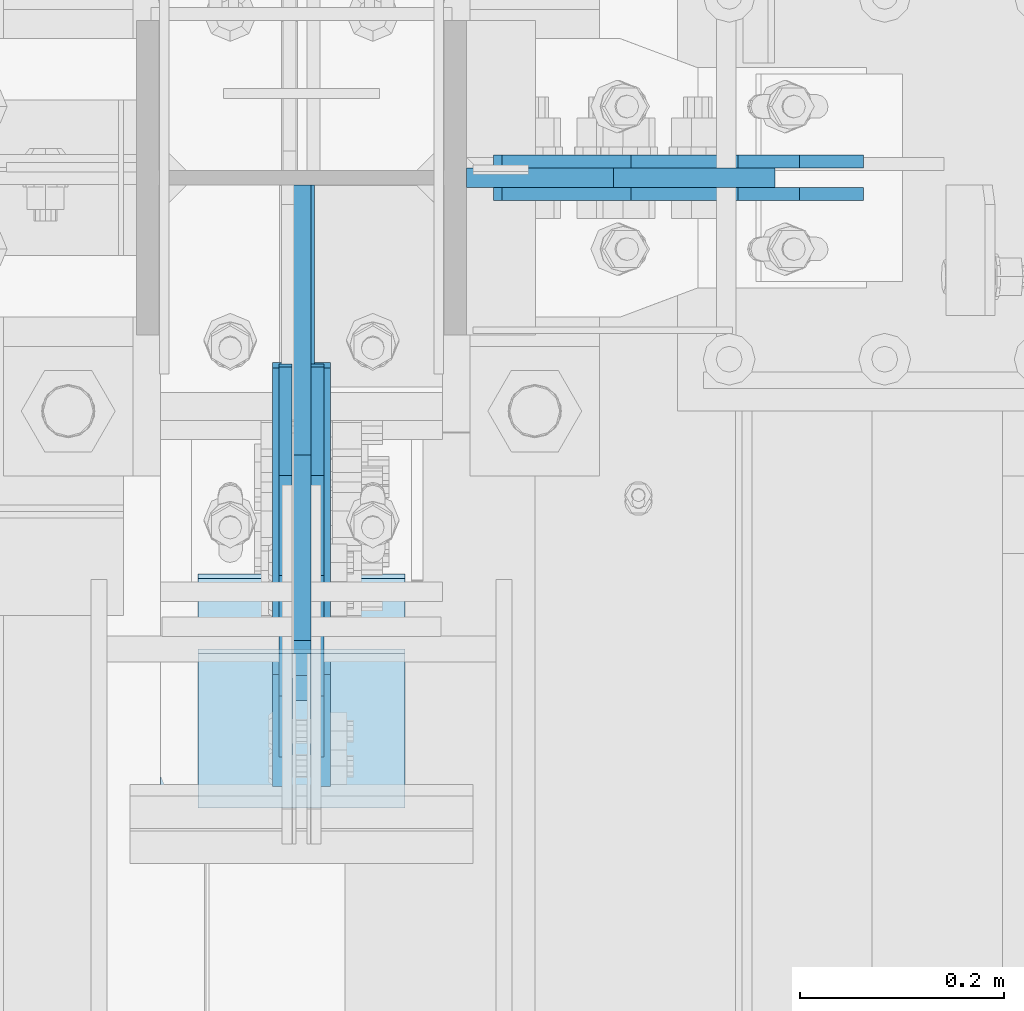
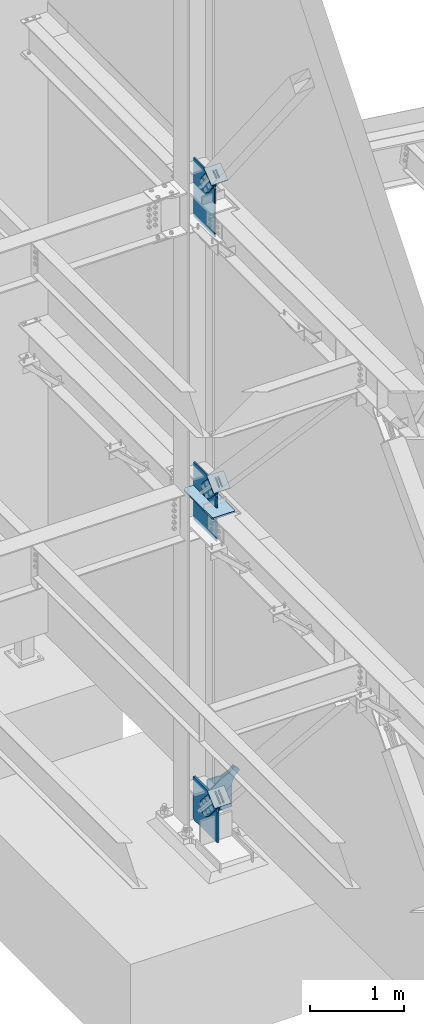
# One storey, part 1090 of 1179: 16 plates, 12 elements without a shape of their own.
"""IFC2X3 building model written with IfcOpenShell, lengths in millimetres."""

from ifc_helpers import new_model, si_unit, frame, origin_with_axes, place, context, subcontext, project, spatial, faceted_brep, material, type_object, element, aggregate, save


model = new_model("IFC2X3")

# Units and contexts
model_context = context("Model", 3, precision=1e-05, world=origin_with_axes())
body_context = subcontext(model_context, "Body", "Model", "MODEL_VIEW")
ifc_project = project(units=[si_unit("LENGTHUNIT", "METRE", prefix="MILLI"), si_unit("AREAUNIT", "SQUARE_METRE"), si_unit("VOLUMEUNIT", "CUBIC_METRE"), si_unit("MASSUNIT", "GRAM", prefix="KILO"), si_unit("TIMEUNIT", "SECOND"), si_unit("PLANEANGLEUNIT", "RADIAN"), si_unit("SOLIDANGLEUNIT", "STERADIAN"), si_unit("THERMODYNAMICTEMPERATUREUNIT", "DEGREE_CELSIUS"), si_unit("LUMINOUSINTENSITYUNIT", "LUMEN")], contexts=[model_context])

# Site, building, storey
site_placement = place(None, origin_with_axes())
site = spatial("IfcSite", under=ifc_project, at=site_placement, CompositionType="ELEMENT")
building_placement = place(site_placement, origin_with_axes())
building = spatial("IfcBuilding", under=site, at=building_placement, Name="Undefined", CompositionType="ELEMENT")
storey_placement = place(building_placement, origin_with_axes())
storey = spatial("IfcBuildingStorey", under=building, at=storey_placement, Name="Undefined", CompositionType="ELEMENT", Elevation=0.0)

# Assembly, plate
assembly_1_placement = place(storey_placement, origin_with_axes())
assembly_1 = element("IfcElementAssembly", 1, at=assembly_1_placement, inside=storey, AssemblyPlace="NOTDEFINED", PredefinedType="RIGID_FRAME")
ifc_material_1 = material(Name="STEEL/A36")
plate_type_1 = type_object("IfcPlateType", PredefinedType="NOTDEFINED")
plate_1_placement = place(assembly_1_placement, frame((24798.1057246051, 34407.475, 178.905330865056), z_axis=(-0.682177697050866, 0.0, 0.731186426054517), x_axis=(0.73118642605452, 0.0, 0.682177697050862)))
plate_1 = element("IfcPlate", 2, at=plate_1_placement, type_object=plate_type_1, material=ifc_material_1, context=body_context, shape_type="Brep", body=[
    faceted_brep([(0.0, -6.34999999999854, 0.0), (-101.600000000211, -6.34999999999854, -44.6881937825565), (-101.600000000211, 6.34999999999854, -44.6881937825565), (0.0, 6.34999999999854, 0.0), (-246.684985848258, -6.34999999999854, -44.6881937827675), (-246.684985848258, 6.34999999999854, -44.6881937827675), (-281.313054102191, -6.34999999999854, -37.800242748639), (-281.313054102191, 6.34999999999854, -37.800242748639), (-310.669312868691, -6.34999999999854, -18.1850177516608), (-310.669312868691, 6.34999999999854, -18.1850177516608), (-330.284537865713, -6.34999999999854, 11.1712410148393), (-330.284537865713, 6.34999999999854, 11.1712410148393), (-337.172488899912, -6.34999999999854, 45.7993031647638), (-337.172488899912, 6.34999999999854, 45.7993031647638), (-330.284537865768, -6.34999999999854, 80.4273714187839), (-330.284537865768, 6.34999999999854, 80.4273714187839), (-310.669312868773, -6.34999999999854, 109.783630185371), (-310.669312868773, 6.34999999999854, 109.783630185371), (-281.313054102271, -6.34999999999854, 129.398855182466), (-281.313054102271, 6.34999999999854, 129.398855182466), (-246.684988899762, -6.34999999999854, 136.286806216707), (-246.684988899762, 6.34999999999854, 136.286806216707), (-101.600000000377, -6.34999999999854, 136.286806216911), (-101.600000000377, 6.34999999999854, 136.286806216911), (-8.18545231595635e-11, -6.34999999999854, 91.5986124346418), (-8.18545231595635e-11, 6.34999999999854, 91.5986124346418), (82.5500000001266, -6.34999999999854, 91.5986124347546), (82.5500000001266, 6.34999999999854, 91.5986124347546), (82.550000000203, -6.34999999999854, 1.2732925824821e-10), (82.550000000203, 6.34999999999854, 1.2732925824821e-10)], [[[0, 1, 2, 3]], [[1, 4, 5, 2]], [[4, 6, 7, 5]], [[6, 8, 9, 7]], [[8, 10, 11, 9]], [[10, 12, 13, 11]], [[12, 14, 15, 13]], [[14, 16, 17, 15]], [[16, 18, 19, 17]], [[18, 20, 21, 19]], [[20, 22, 23, 21]], [[22, 24, 25, 23]], [[24, 26, 27, 25]], [[26, 28, 29, 27]], [[28, 0, 3, 29]], [[5, 7, 9, 11, 13, 15, 17, 19, 21, 23, 25, 27, 29, 3, 2]], [[28, 26, 24, 22, 20, 18, 16, 14, 12, 10, 8, 6, 4, 1, 0]]]),
])
aggregate(assembly_1, [plate_1])

assembly_2_placement = place(storey_placement, origin_with_axes())
assembly_2 = element("IfcElementAssembly", 3, at=assembly_2_placement, inside=storey, AssemblyPlace="NOTDEFINED", PredefinedType="RIGID_FRAME")
plate_2_placement = place(assembly_2_placement, frame((24798.1057246051, 34375.725, 178.905330865056), z_axis=(-0.682177697050866, 0.0, 0.731186426054517), x_axis=(0.73118642605452, 0.0, 0.682177697050862)))
plate_2 = element("IfcPlate", 4, at=plate_2_placement, type_object=plate_type_1, material=ifc_material_1, context=body_context, shape_type="Brep", body=[
    faceted_brep([(0.0, -6.34999999999854, 0.0), (-101.600000000211, -6.34999999999854, -44.6881937825565), (-101.600000000211, 6.34999999999854, -44.6881937825565), (0.0, 6.34999999999854, 0.0), (-246.684985848258, -6.34999999999854, -44.6881937827675), (-246.684985848258, 6.34999999999854, -44.6881937827675), (-281.313054102191, -6.34999999999854, -37.800242748639), (-281.313054102191, 6.34999999999854, -37.800242748639), (-310.669312868691, -6.34999999999854, -18.1850177516608), (-310.669312868691, 6.34999999999854, -18.1850177516608), (-330.284537865713, -6.34999999999854, 11.1712410148393), (-330.284537865713, 6.34999999999854, 11.1712410148393), (-337.172488899912, -6.34999999999854, 45.7993031647638), (-337.172488899912, 6.34999999999854, 45.7993031647638), (-330.284537865768, -6.34999999999854, 80.4273714187839), (-330.284537865768, 6.34999999999854, 80.4273714187839), (-310.669312868773, -6.34999999999854, 109.783630185371), (-310.669312868773, 6.34999999999854, 109.783630185371), (-281.313054102271, -6.34999999999854, 129.398855182466), (-281.313054102271, 6.34999999999854, 129.398855182466), (-246.684988899762, -6.34999999999854, 136.286806216707), (-246.684988899762, 6.34999999999854, 136.286806216707), (-101.600000000377, -6.34999999999854, 136.286806216911), (-101.600000000377, 6.34999999999854, 136.286806216911), (-8.18545231595635e-11, -6.34999999999854, 91.5986124346418), (-8.18545231595635e-11, 6.34999999999854, 91.5986124346418), (82.5500000001266, -6.34999999999854, 91.5986124347546), (82.5500000001266, 6.34999999999854, 91.5986124347546), (82.550000000203, -6.34999999999854, 1.2732925824821e-10), (82.550000000203, 6.34999999999854, 1.2732925824821e-10)], [[[0, 1, 2, 3]], [[1, 4, 5, 2]], [[4, 6, 7, 5]], [[6, 8, 9, 7]], [[8, 10, 11, 9]], [[10, 12, 13, 11]], [[12, 14, 15, 13]], [[14, 16, 17, 15]], [[16, 18, 19, 17]], [[18, 20, 21, 19]], [[20, 22, 23, 21]], [[22, 24, 25, 23]], [[24, 26, 27, 25]], [[26, 28, 29, 27]], [[28, 0, 3, 29]], [[5, 7, 9, 11, 13, 15, 17, 19, 21, 23, 25, 27, 29, 3, 2]], [[28, 26, 24, 22, 20, 18, 16, 14, 12, 10, 8, 6, 4, 1, 0]]]),
])
aggregate(assembly_2, [plate_2])

assembly_3_placement = place(storey_placement, origin_with_axes())
assembly_3 = element("IfcElementAssembly", 5, at=assembly_3_placement, inside=storey, AssemblyPlace="NOTDEFINED", PredefinedType="RIGID_FRAME")
plate_3_placement = place(assembly_3_placement, frame((24291.925, 33955.4297504539, 8429.1005762594), z_axis=(0.0, -0.784153429306135, -0.620566998242276), x_axis=(0.0, 0.620566998242269, -0.78415342930614)))
plate_3 = element("IfcPlate", 6, at=plate_3_placement, type_object=plate_type_1, material=ifc_material_1, context=body_context, shape_type="Brep", body=[
    faceted_brep([(0.0, -6.34999999999854, 0.0), (-8.18545231595635e-11, -6.34999999999854, 91.5986124346418), (-8.18545231595635e-11, 6.34999999999854, 91.5986124346418), (0.0, 6.34999999999854, 0.0), (74.9300000003022, -6.34999999999854, 91.5986124341325), (74.9300000003022, 6.34999999999854, 91.5986124341325), (176.530000001621, -6.34999999999854, 136.28680621547), (176.530000001621, 6.34999999999854, 136.28680621547), (321.614985851276, -6.34999999999854, 136.286806215194), (321.614985851276, 6.34999999999854, 136.286806215194), (356.243054105249, -6.34999999999854, 129.398855180967), (356.243054105249, 6.34999999999854, 129.398855180967), (385.599312871764, -6.34999999999854, 109.78363018396), (385.599312871764, 6.34999999999854, 109.78363018396), (405.214537868786, -6.34999999999854, 80.4273714174888), (405.214537868786, 6.34999999999854, 80.4273714174888), (412.10248890298, -6.34999999999854, 45.7993092690194), (412.10248890298, 6.34999999999854, 45.7993092690194), (405.214537868789, -6.34999999999854, 11.1712410150285), (405.214537868789, 6.34999999999854, 11.1712410150285), (385.599312871695, -6.34999999999854, -18.1850177515043), (385.599312871695, 6.34999999999854, -18.1850177515043), (356.243054105063, -6.34999999999854, -37.8002427485044), (356.243054105063, 6.34999999999854, -37.8002427485044), (321.614988902153, -6.34999999999854, -44.6881937826292), (321.614988902153, 6.34999999999854, -44.6881937826292), (176.530000001738, -6.34999999999854, -44.6881937823491), (176.530000001738, 6.34999999999854, -44.6881937823491), (74.9300000005605, -6.34999999999854, 6.91215973347425e-11), (74.9300000005605, 6.34999999999854, 6.91215973347425e-11)], [[[0, 1, 2, 3]], [[1, 4, 5, 2]], [[4, 6, 7, 5]], [[6, 8, 9, 7]], [[8, 10, 11, 9]], [[10, 12, 13, 11]], [[12, 14, 15, 13]], [[14, 16, 17, 15]], [[16, 18, 19, 17]], [[18, 20, 21, 19]], [[20, 22, 23, 21]], [[22, 24, 25, 23]], [[24, 26, 27, 25]], [[26, 28, 29, 27]], [[28, 0, 3, 29]], [[5, 7, 9, 11, 13, 15, 17, 19, 21, 23, 25, 27, 29, 3, 2]], [[28, 26, 24, 22, 20, 18, 16, 14, 12, 10, 8, 6, 4, 1, 0]]]),
])
aggregate(assembly_3, [plate_3])

assembly_4_placement = place(storey_placement, origin_with_axes())
assembly_4 = element("IfcElementAssembly", 7, at=assembly_4_placement, inside=storey, AssemblyPlace="NOTDEFINED", PredefinedType="RIGID_FRAME")
plate_4_placement = place(assembly_4_placement, frame((24323.675, 33955.4297504539, 8429.1005762594), z_axis=(0.0, -0.784153429306135, -0.620566998242276), x_axis=(0.0, 0.620566998242269, -0.78415342930614)))
plate_4 = element("IfcPlate", 8, at=plate_4_placement, type_object=plate_type_1, material=ifc_material_1, context=body_context, shape_type="Brep", body=[
    faceted_brep([(0.0, -6.34999999999854, 0.0), (-8.18545231595635e-11, -6.34999999999854, 91.5986124346418), (-8.18545231595635e-11, 6.34999999999854, 91.5986124346418), (0.0, 6.34999999999854, 0.0), (74.9300000003022, -6.34999999999854, 91.5986124341325), (74.9300000003022, 6.34999999999854, 91.5986124341325), (176.530000001621, -6.34999999999854, 136.28680621547), (176.530000001621, 6.34999999999854, 136.28680621547), (321.614985851276, -6.34999999999854, 136.286806215194), (321.614985851276, 6.34999999999854, 136.286806215194), (356.243054105249, -6.34999999999854, 129.398855180967), (356.243054105249, 6.34999999999854, 129.398855180967), (385.599312871764, -6.34999999999854, 109.78363018396), (385.599312871764, 6.34999999999854, 109.78363018396), (405.214537868786, -6.34999999999854, 80.4273714174888), (405.214537868786, 6.34999999999854, 80.4273714174888), (412.10248890298, -6.34999999999854, 45.7993092690194), (412.10248890298, 6.34999999999854, 45.7993092690194), (405.214537868789, -6.34999999999854, 11.1712410150285), (405.214537868789, 6.34999999999854, 11.1712410150285), (385.599312871695, -6.34999999999854, -18.1850177515043), (385.599312871695, 6.34999999999854, -18.1850177515043), (356.243054105063, -6.34999999999854, -37.8002427485044), (356.243054105063, 6.34999999999854, -37.8002427485044), (321.614988902153, -6.34999999999854, -44.6881937826292), (321.614988902153, 6.34999999999854, -44.6881937826292), (176.530000001738, -6.34999999999854, -44.6881937823491), (176.530000001738, 6.34999999999854, -44.6881937823491), (74.9300000005605, -6.34999999999854, 6.91215973347425e-11), (74.9300000005605, 6.34999999999854, 6.91215973347425e-11)], [[[0, 1, 2, 3]], [[1, 4, 5, 2]], [[4, 6, 7, 5]], [[6, 8, 9, 7]], [[8, 10, 11, 9]], [[10, 12, 13, 11]], [[12, 14, 15, 13]], [[14, 16, 17, 15]], [[16, 18, 19, 17]], [[18, 20, 21, 19]], [[20, 22, 23, 21]], [[22, 24, 25, 23]], [[24, 26, 27, 25]], [[26, 28, 29, 27]], [[28, 0, 3, 29]], [[5, 7, 9, 11, 13, 15, 17, 19, 21, 23, 25, 27, 29, 3, 2]], [[28, 26, 24, 22, 20, 18, 16, 14, 12, 10, 8, 6, 4, 1, 0]]]),
])
aggregate(assembly_4, [plate_4])

assembly_5_placement = place(storey_placement, origin_with_axes())
assembly_5 = element("IfcElementAssembly", 9, at=assembly_5_placement, inside=storey, Name="Plate", AssemblyPlace="NOTDEFINED", PredefinedType="RIGID_FRAME")
plate_type_2 = type_object("IfcPlateType", PredefinedType="NOTDEFINED")
plate_5_placement = place(assembly_5_placement, frame((24206.2, 33841.816379224, 8335.13974412105), z_axis=(0.0, 0.784153429306134, 0.620566998242277), x_axis=(1.0, 0.0, 0.0)))
plate_5 = element("IfcPlate", 10, at=plate_5_placement, type_object=plate_type_2, material=ifc_material_1, Name="Plate", context=body_context, shape_type="Brep", body=[
    faceted_brep([(0.0, -3.17500000000109, 0.0), (0.0, -3.17500000000291, 203.200000000368), (0.0, 3.17499999998836, 203.200000000361), (0.0, 3.17500000000109, 7.27595761418343e-12), (203.199999999997, -3.17500000000291, 203.200000000368), (203.199999999997, 3.17499999998836, 203.200000000361), (203.199999999997, -3.17499999999927, 3.63797880709171e-12), (203.199999999997, 3.17499999999382, -3.63797880709171e-12)], [[[0, 1, 2, 3]], [[1, 4, 5, 2]], [[4, 6, 7, 5]], [[6, 0, 3, 7]], [[5, 7, 3, 2]], [[6, 4, 1, 0]]]),
])
aggregate(assembly_5, [plate_5])

assembly_6_placement = place(storey_placement, origin_with_axes())
assembly_6 = element("IfcElementAssembly", 11, at=assembly_6_placement, inside=storey, Name="Plate", AssemblyPlace="NOTDEFINED", PredefinedType="RIGID_FRAME")
plate_6_placement = place(assembly_6_placement, frame((24206.2, 33792.918136432, 4382.10915289215), z_axis=(0.0, 0.729241792887681, 0.684256097894612), x_axis=(1.0, 0.0, 0.0)))
plate_6 = element("IfcPlate", 12, at=plate_6_placement, type_object=plate_type_2, material=ifc_material_1, Name="Plate", context=body_context, shape_type="Brep", body=[
    faceted_brep([(0.0, -3.17500000000109, 0.0), (0.0, -3.17500000000291, 203.200000000368), (0.0, 3.17499999998836, 203.200000000361), (0.0, 3.17500000000109, 7.27595761418343e-12), (203.199999999997, -3.17500000000291, 203.200000000368), (203.199999999997, 3.17499999998836, 203.200000000361), (203.199999999997, -3.17499999999927, 3.63797880709171e-12), (203.199999999997, 3.17499999999382, -3.63797880709171e-12)], [[[0, 1, 2, 3]], [[1, 4, 5, 2]], [[4, 6, 7, 5]], [[6, 0, 3, 7]], [[5, 7, 3, 2]], [[6, 4, 1, 0]]]),
])
aggregate(assembly_6, [plate_6])

assembly_7_placement = place(storey_placement, origin_with_axes())
assembly_7 = element("IfcElementAssembly", 13, at=assembly_7_placement, inside=storey, Name="Plate", AssemblyPlace="NOTDEFINED", PredefinedType="RIGID_FRAME")
plate_7_placement = place(assembly_7_placement, frame((24206.2, 33776.2283892887, 320.431185750051), z_axis=(0.0, 0.745753571678113, 0.666221892712434), x_axis=(1.0, 0.0, 0.0)))
plate_7 = element("IfcPlate", 14, at=plate_7_placement, type_object=plate_type_2, material=ifc_material_1, Name="Plate", context=body_context, shape_type="Brep", body=[
    faceted_brep([(0.0, -3.17500000000109, 0.0), (0.0, -3.17500000000291, 203.200000000368), (0.0, 3.17499999998836, 203.200000000361), (0.0, 3.17500000000109, 7.27595761418343e-12), (203.199999999997, -3.17500000000291, 203.200000000368), (203.199999999997, 3.17499999998836, 203.200000000361), (203.199999999997, -3.17499999999927, 3.63797880709171e-12), (203.199999999997, 3.17499999999382, -3.63797880709171e-12)], [[[0, 1, 2, 3]], [[1, 4, 5, 2]], [[4, 6, 7, 5]], [[6, 0, 3, 7]], [[5, 7, 3, 2]], [[6, 4, 1, 0]]]),
])
aggregate(assembly_7, [plate_7])

# Assembly, plates
assembly_8_placement = place(storey_placement, origin_with_axes())
assembly_8 = element("IfcElementAssembly", 15, at=assembly_8_placement, inside=storey, Name="COLUMN", AssemblyPlace="NOTDEFINED", PredefinedType="RIGID_FRAME")
ifc_material_2 = material(Name="STEEL/A572-GR.50")
plate_type_3 = type_object("IfcPlateType", PredefinedType="NOTDEFINED")
plate_8_placement = place(assembly_8_placement, frame((24169.6874938965, 33751.6169989338, 4090.9875), z_axis=(0.0, 1.0, 0.0), x_axis=(1.0, 0.0, 0.0)))
plate_8 = element("IfcPlate", 16, at=plate_8_placement, type_object=plate_type_3, material=ifc_material_2, Name="PLATE", context=body_context, shape_type="Brep", body=[
    faceted_brep([(127.000006103513, -11.1125000000002, 632.839251066151), (127.000006103513, -11.1125000000002, 153.987500190735), (127.000006103513, 11.1125000000002, 153.987500190735), (127.000006103513, 11.1125000000002, 632.839251066151), (127.845894812999, -11.1125000000002, 149.734930475584), (127.845894812999, 11.1125000000002, 149.734930475584), (130.254782053442, -11.1125000000002, 146.129775949928), (130.254782053442, 11.1125000000002, 146.129775949928), (133.859936579101, -11.1125000000002, 143.720888709489), (133.859936579101, 11.1125000000002, 143.720888709489), (138.112505912784, -11.1125000000002, 142.875), (138.112505912784, 11.1125000000002, 142.875), (142.365075627931, -11.1125000000002, 143.720888709489), (142.365075627931, 11.1125000000002, 143.720888709489), (145.970230153591, -11.1125000000002, 146.129775949928), (145.970230153591, 11.1125000000002, 146.129775949928), (148.379117394034, -11.1125000000002, 149.734930475584), (148.379117394034, 11.1125000000002, 149.734930475584), (149.225006103519, -11.1125000000002, 153.987500190735), (149.225006103519, 11.1125000000002, 153.987500190735), (149.225006103519, -11.1125000000002, 632.839251066151), (149.225006103519, 11.1125000000002, 632.839251066151), (0.0, -11.1125000000002, 607.43925144762), (25.3999996185303, -11.1125000000002, 632.839251066151), (25.3999996185303, 11.1125000000002, 632.839251066151), (0.0, 11.1125000000002, 607.43925144762), (0.0, -11.1125000000002, 19.0499992370605), (0.0, 11.1125000000002, 19.0499992370605), (7.9375, -11.1125000000002, 0.0), (7.9375, 11.1125000000002, 0.0), (268.287506103516, -11.1125000000002, 0.0), (268.287506103516, 11.1125000000002, 0.0), (276.225006103516, -11.1125000000002, 19.0499992370605), (276.225006103516, 11.1125000000002, 19.0499992370605), (276.225006103516, -11.1125000000002, 607.43925144762), (276.225006103516, 11.1125000000002, 607.43925144762), (250.825006484985, -11.1125000000002, 632.839251066151), (250.825006484985, 11.1125000000002, 632.839251066151)], [[[0, 1, 2, 3]], [[4, 5, 2, 1]], [[6, 7, 5, 4]], [[8, 9, 7, 6]], [[10, 11, 9, 8]], [[12, 13, 11, 10]], [[14, 15, 13, 12]], [[16, 17, 15, 14]], [[18, 19, 17, 16]], [[20, 21, 19, 18]], [[22, 23, 24, 25]], [[26, 22, 25, 27]], [[28, 26, 27, 29]], [[30, 28, 29, 31]], [[32, 30, 31, 33]], [[34, 32, 33, 35]], [[36, 34, 35, 37]], [[16, 14, 12, 10, 8, 6, 4, 1, 0, 23, 22, 26, 28, 30, 32, 34, 36, 20, 18]], [[24, 23, 0, 3]], [[37, 35, 33, 31, 29, 27, 25, 24, 3, 2, 5, 7, 9, 11, 13, 15, 17, 19, 21]], [[36, 37, 21, 20]]]),
])
plate_type_4 = type_object("IfcPlateType", PredefinedType="NOTDEFINED")
plate_9_placement = place(assembly_8_placement, frame((24469.725, 34391.6, -215.9), z_axis=(0.0, 0.0, 1.0), x_axis=(1.0, 0.0, 0.0)))
plate_9 = element("IfcPlate", 17, at=plate_9_placement, type_object=plate_type_4, material=ifc_material_2, Name="PLATE", context=body_context, shape_type="Brep", body=[
    faceted_brep([(0.0, -9.52500000000146, 19.0499992370605), (0.0, -9.52500000000146, 443.719274822156), (0.0, 9.52500000000146, 443.719274822156), (0.0, 9.52500000000146, 19.0499992370605), (143.793050608023, -9.52500000000146, 443.719274822156), (143.793050608023, 9.52500000000146, 443.719274822156), (301.904786341987, -9.52500000000146, 274.24854092337), (301.904786341987, 9.52500000000146, 274.24854092337), (301.904786341987, -9.52500000000146, 2.8421709430404e-14), (301.904786341987, 9.52500000000146, 2.8421709430404e-14), (19.0499992370605, -9.52500000000146, 0.0), (19.0499992370605, 9.52500000000146, 0.0)], [[[0, 1, 2, 3]], [[1, 4, 5, 2]], [[4, 6, 7, 5]], [[6, 8, 9, 7]], [[8, 10, 11, 9]], [[10, 0, 3, 11]], [[5, 7, 9, 11, 3, 2]], [[10, 8, 6, 4, 1, 0]]]),
])

# Assembly, plate
assembly_9_placement = place(storey_placement, origin_with_axes())
assembly_9 = element("IfcElementAssembly", 18, at=assembly_9_placement, inside=storey, AssemblyPlace="NOTDEFINED", PredefinedType="RIGID_FRAME")
plate_type_5 = type_object("IfcPlateType", PredefinedType="NOTDEFINED")
plate_10_placement = place(assembly_9_placement, frame((24291.925, 33905.7415595148, 4492.3265266318), z_axis=(0.0, -0.729241792887679, -0.684256097894614), x_axis=(0.0, 0.684256097894613, -0.72924179288768)))
plate_10 = element("IfcPlate", 19, at=plate_10_placement, type_object=plate_type_5, material=ifc_material_1, context=body_context, shape_type="Brep", body=[
    faceted_brep([(0.0, -6.34999999999854, 0.0), (-4.35647962149233e-10, -6.34999999999854, 112.184930806416), (-4.35647962149233e-10, 6.34999999999854, 112.184930806416), (0.0, 6.34999999999854, 0.0), (82.5499999996491, -6.34999999999854, 112.184930806461), (82.5499999996491, 6.34999999999854, 112.184930806461), (184.149999999618, -6.34999999999854, 149.75496540347), (184.149999999618, 6.34999999999854, 149.75496540347), (327.919242323534, -6.34999999999854, 149.754965403559), (327.919242323534, 6.34999999999854, 149.754965403559), (363.762328723451, -6.34999999999854, 142.625332233587), (363.762328723451, 6.34999999999854, 142.625332233587), (394.148630137406, -6.34999999999854, 122.321854743475), (394.148630137406, 6.34999999999854, 122.321854743475), (414.452107627645, -6.34999999999854, 91.9355533295929), (414.452107627645, 6.34999999999854, 91.9355533295929), (421.581740797776, -6.34999999999854, 56.0924638777396), (421.581740797776, 6.34999999999854, 56.0924638777396), (414.452107627878, -6.34999999999854, 20.2493774776722), (414.452107627878, 6.34999999999854, 20.2493774776722), (394.14863013775, -6.34999999999854, -10.1369239363994), (394.14863013775, 6.34999999999854, -10.1369239363994), (363.762328723789, -6.34999999999854, -30.4404014266784), (363.762328723789, 6.34999999999854, -30.4404014266784), (327.919240798041, -6.34999999999854, -37.570034596738), (327.919240798041, 6.34999999999854, -37.570034596738), (184.150000000338, -6.34999999999854, -37.5700345968289), (184.150000000338, 6.34999999999854, -37.5700345968289), (82.550000000203, -6.34999999999854, 1.2732925824821e-10), (82.550000000203, 6.34999999999854, 1.2732925824821e-10)], [[[0, 1, 2, 3]], [[1, 4, 5, 2]], [[4, 6, 7, 5]], [[6, 8, 9, 7]], [[8, 10, 11, 9]], [[10, 12, 13, 11]], [[12, 14, 15, 13]], [[14, 16, 17, 15]], [[16, 18, 19, 17]], [[18, 20, 21, 19]], [[20, 22, 23, 21]], [[22, 24, 25, 23]], [[24, 26, 27, 25]], [[26, 28, 29, 27]], [[28, 0, 3, 29]], [[5, 7, 9, 11, 13, 15, 17, 19, 21, 23, 25, 27, 29, 3, 2]], [[28, 26, 24, 22, 20, 18, 16, 14, 12, 10, 8, 6, 4, 1, 0]]]),
])
aggregate(assembly_9, [plate_10])

assembly_10_placement = place(storey_placement, origin_with_axes())
assembly_10 = element("IfcElementAssembly", 20, at=assembly_10_placement, inside=storey, AssemblyPlace="NOTDEFINED", PredefinedType="RIGID_FRAME")
plate_11_placement = place(assembly_10_placement, frame((24323.675, 33905.7415595148, 4492.3265266318), z_axis=(0.0, -0.729241792887679, -0.684256097894614), x_axis=(0.0, 0.684256097894613, -0.72924179288768)))
plate_11 = element("IfcPlate", 21, at=plate_11_placement, type_object=plate_type_5, material=ifc_material_1, context=body_context, shape_type="Brep", body=[
    faceted_brep([(0.0, -6.34999999999854, 0.0), (-4.35647962149233e-10, -6.34999999999854, 112.184930806416), (-4.35647962149233e-10, 6.34999999999854, 112.184930806416), (0.0, 6.34999999999854, 0.0), (82.5499999996491, -6.34999999999854, 112.184930806461), (82.5499999996491, 6.34999999999854, 112.184930806461), (184.149999999618, -6.34999999999854, 149.75496540347), (184.149999999618, 6.34999999999854, 149.75496540347), (327.919242323534, -6.34999999999854, 149.754965403559), (327.919242323534, 6.34999999999854, 149.754965403559), (363.762328723451, -6.34999999999854, 142.625332233587), (363.762328723451, 6.34999999999854, 142.625332233587), (394.148630137406, -6.34999999999854, 122.321854743475), (394.148630137406, 6.34999999999854, 122.321854743475), (414.452107627645, -6.34999999999854, 91.9355533295929), (414.452107627645, 6.34999999999854, 91.9355533295929), (421.581740797776, -6.34999999999854, 56.0924638777396), (421.581740797776, 6.34999999999854, 56.0924638777396), (414.452107627878, -6.34999999999854, 20.2493774776722), (414.452107627878, 6.34999999999854, 20.2493774776722), (394.14863013775, -6.34999999999854, -10.1369239363994), (394.14863013775, 6.34999999999854, -10.1369239363994), (363.762328723789, -6.34999999999854, -30.4404014266784), (363.762328723789, 6.34999999999854, -30.4404014266784), (327.919240798041, -6.34999999999854, -37.570034596738), (327.919240798041, 6.34999999999854, -37.570034596738), (184.150000000338, -6.34999999999854, -37.5700345968289), (184.150000000338, 6.34999999999854, -37.5700345968289), (82.550000000203, -6.34999999999854, 1.2732925824821e-10), (82.550000000203, 6.34999999999854, 1.2732925824821e-10)], [[[0, 1, 2, 3]], [[1, 4, 5, 2]], [[4, 6, 7, 5]], [[6, 8, 9, 7]], [[8, 10, 11, 9]], [[10, 12, 13, 11]], [[12, 14, 15, 13]], [[14, 16, 17, 15]], [[16, 18, 19, 17]], [[18, 20, 21, 19]], [[20, 22, 23, 21]], [[22, 24, 25, 23]], [[24, 26, 27, 25]], [[26, 28, 29, 27]], [[28, 0, 3, 29]], [[5, 7, 9, 11, 13, 15, 17, 19, 21, 23, 25, 27, 29, 3, 2]], [[28, 26, 24, 22, 20, 18, 16, 14, 12, 10, 8, 6, 4, 1, 0]]]),
])
aggregate(assembly_10, [plate_11])

# Plate
plate_type_6 = type_object("IfcPlateType", PredefinedType="NOTDEFINED")
plate_12_placement = place(assembly_8_placement, frame((24307.8, 34384.45625, 3663.95), z_axis=(0.0, 0.0, 1.0), x_axis=(0.0, -1.0, 0.0)))
plate_12 = element("IfcPlate", 22, at=plate_12_placement, type_object=plate_type_6, material=ifc_material_2, Name="PLATE", context=body_context, shape_type="Brep", body=[
    faceted_brep([(0.0, -9.52499999999964, 0.0), (0.0, -9.52499999999998, 737.174280571875), (0.0, 9.52499999999998, 737.174280571875), (0.0, 9.52499999999964, 0.0), (306.78854913477, -9.52500000000146, 737.174280632707), (306.78854913477, 9.52500000000146, 737.174280632707), (480.439251066149, -9.52500000000146, 574.235797321552), (480.439251066149, 9.52500000000146, 574.235797321552), (480.439251066149, -9.52500000000146, 1.36424205265939e-12), (480.439251066149, 9.52500000000146, 1.36424205265939e-12)], [[[0, 1, 2, 3]], [[1, 4, 5, 2]], [[4, 6, 7, 5]], [[6, 8, 9, 7]], [[8, 0, 3, 9]], [[5, 7, 9, 3, 2]], [[8, 6, 4, 1, 0]]]),
])

plate_type_7 = type_object("IfcPlateType", PredefinedType="NOTDEFINED")
plate_13_placement = place(assembly_8_placement, frame((24307.8, 34384.45625, -215.9), z_axis=(0.0, 0.0, 1.0), x_axis=(0.0, -1.0, 0.0)))
plate_13 = element("IfcPlate", 23, at=plate_13_placement, type_object=plate_type_7, material=ifc_material_2, Name="PLATE", context=body_context, shape_type="Brep", body=[
    faceted_brep([(0.0, -12.7000000000007, 19.0500000000029), (0.0, -12.7000000000007, 553.224676908997), (0.0, 12.7000000000007, 553.224676908997), (0.0, 12.7000000000007, 19.0500000000029), (325.299029580507, -12.7000000000007, 553.224676908997), (325.299029580507, 12.7000000000007, 553.224676908997), (505.249366426433, -12.7000000000007, 392.465334197486), (505.249366426433, 12.7000000000007, 392.465334197486), (505.249366426433, -12.7000000000007, 0.0), (505.249366426433, 12.7000000000007, 0.0), (19.0499992370605, -12.6999999999971, 0.0), (19.0499992370605, 12.6999999999971, 0.0)], [[[0, 1, 2, 3]], [[1, 4, 5, 2]], [[4, 6, 7, 5]], [[6, 8, 9, 7]], [[8, 10, 11, 9]], [[10, 0, 3, 11]], [[5, 7, 9, 11, 3, 2]], [[10, 8, 6, 4, 1, 0]]]),
])

# Assembly, plate
assembly_11_placement = place(storey_placement, origin_with_axes())
assembly_11 = element("IfcElementAssembly", 24, at=assembly_11_placement, inside=storey, AssemblyPlace="NOTDEFINED", PredefinedType="RIGID_FRAME")
plate_type_8 = type_object("IfcPlateType", PredefinedType="NOTDEFINED")
plate_14_placement = place(assembly_11_placement, frame((24287.1625, 33904.6591023429, 439.422708016933), z_axis=(0.0, -0.74575357167811, -0.666221892712438), x_axis=(0.0, 0.666221892712438, -0.74575357167811)))
plate_14 = element("IfcPlate", 25, at=plate_14_placement, type_object=plate_type_8, material=ifc_material_1, context=body_context, shape_type="Brep", body=[
    faceted_brep([(0.0, -7.9375, 0.0), (-8.00355337560177e-11, -7.9375, 146.904840309817), (-8.00355337560177e-11, 7.9375, 146.904840309817), (0.0, 7.9375, 0.0), (77.4700000003613, -7.9375, 146.904840309813), (77.4700000003613, 7.9375, 146.904840309813), (179.070000002353, -7.9375, 168.702420152476), (179.070000002353, 7.9375, 168.702420152476), (398.391138856361, -7.9375, 168.70242015224), (398.391138856361, 7.9375, 168.70242015224), (434.841735789174, -7.9375, 161.451945623932), (434.841735789174, 7.9375, 161.451945623932), (465.743059764452, -7.9375, 140.804341060317), (465.743059764452, 7.9375, 140.804341060317), (486.390664328166, -7.9375, 109.903017085191), (486.390664328166, 7.9375, 109.903017085191), (493.641138856514, -7.9375, 73.4524201550448), (493.641138856514, 7.9375, 73.4524201550448), (486.390664328224, -7.9375, 37.0018232223083), (486.390664328224, 7.9375, 37.0018232223083), (465.743059764485, -7.9375, 6.10049924709892), (465.743059764485, 7.9375, 6.10049924709892), (434.841735789141, -7.9375, -14.5471053165493), (434.841735789141, 7.9375, -14.5471053165493), (398.39113885527, -7.9375, -21.7975798448133), (398.39113885527, 7.9375, -21.7975798448133), (179.070000002601, -7.9375, -21.7975798445805), (179.070000002601, 7.9375, -21.7975798445805), (77.4700000003904, -7.9375, -5.82076609134674e-11), (77.4700000003904, 7.9375, -5.82076609134674e-11)], [[[0, 1, 2, 3]], [[1, 4, 5, 2]], [[4, 6, 7, 5]], [[6, 8, 9, 7]], [[8, 10, 11, 9]], [[10, 12, 13, 11]], [[12, 14, 15, 13]], [[14, 16, 17, 15]], [[16, 18, 19, 17]], [[18, 20, 21, 19]], [[20, 22, 23, 21]], [[22, 24, 25, 23]], [[24, 26, 27, 25]], [[26, 28, 29, 27]], [[28, 0, 3, 29]], [[5, 7, 9, 11, 13, 15, 17, 19, 21, 23, 25, 27, 29, 3, 2]], [[28, 26, 24, 22, 20, 18, 16, 14, 12, 10, 8, 6, 4, 1, 0]]]),
])
aggregate(assembly_11, [plate_14])

assembly_12_placement = place(storey_placement, origin_with_axes())
assembly_12 = element("IfcElementAssembly", 26, at=assembly_12_placement, inside=storey, AssemblyPlace="NOTDEFINED", PredefinedType="RIGID_FRAME")
plate_15_placement = place(assembly_12_placement, frame((24328.4375, 33904.6591023429, 439.422708016933), z_axis=(0.0, -0.74575357167811, -0.666221892712438), x_axis=(0.0, 0.666221892712438, -0.74575357167811)))
plate_15 = element("IfcPlate", 27, at=plate_15_placement, type_object=plate_type_8, material=ifc_material_1, context=body_context, shape_type="Brep", body=[
    faceted_brep([(0.0, -7.9375, 0.0), (-8.00355337560177e-11, -7.9375, 146.904840309817), (-8.00355337560177e-11, 7.9375, 146.904840309817), (0.0, 7.9375, 0.0), (77.4700000003613, -7.9375, 146.904840309813), (77.4700000003613, 7.9375, 146.904840309813), (179.070000002353, -7.9375, 168.702420152476), (179.070000002353, 7.9375, 168.702420152476), (398.391138856361, -7.9375, 168.70242015224), (398.391138856361, 7.9375, 168.70242015224), (434.841735789174, -7.9375, 161.451945623932), (434.841735789174, 7.9375, 161.451945623932), (465.743059764452, -7.9375, 140.804341060317), (465.743059764452, 7.9375, 140.804341060317), (486.390664328166, -7.9375, 109.903017085191), (486.390664328166, 7.9375, 109.903017085191), (493.641138856514, -7.9375, 73.4524201550448), (493.641138856514, 7.9375, 73.4524201550448), (486.390664328224, -7.9375, 37.0018232223083), (486.390664328224, 7.9375, 37.0018232223083), (465.743059764485, -7.9375, 6.10049924709892), (465.743059764485, 7.9375, 6.10049924709892), (434.841735789141, -7.9375, -14.5471053165493), (434.841735789141, 7.9375, -14.5471053165493), (398.39113885527, -7.9375, -21.7975798448133), (398.39113885527, 7.9375, -21.7975798448133), (179.070000002601, -7.9375, -21.7975798445805), (179.070000002601, 7.9375, -21.7975798445805), (77.4700000003904, -7.9375, -5.82076609134674e-11), (77.4700000003904, 7.9375, -5.82076609134674e-11)], [[[0, 1, 2, 3]], [[1, 4, 5, 2]], [[4, 6, 7, 5]], [[6, 8, 9, 7]], [[8, 10, 11, 9]], [[10, 12, 13, 11]], [[12, 14, 15, 13]], [[14, 16, 17, 15]], [[16, 18, 19, 17]], [[18, 20, 21, 19]], [[20, 22, 23, 21]], [[22, 24, 25, 23]], [[24, 26, 27, 25]], [[26, 28, 29, 27]], [[28, 0, 3, 29]], [[5, 7, 9, 11, 13, 15, 17, 19, 21, 23, 25, 27, 29, 3, 2]], [[28, 26, 24, 22, 20, 18, 16, 14, 12, 10, 8, 6, 4, 1, 0]]]),
])
aggregate(assembly_12, [plate_15])

# Plate
plate_type_9 = type_object("IfcPlateType", PredefinedType="NOTDEFINED")
plate_16_placement = place(assembly_8_placement, frame((24307.8, 34384.45625, 7575.55), z_axis=(0.0, 0.0, 1.0), x_axis=(0.0, -1.0, 0.0)))
plate_16 = element("IfcPlate", 28, at=plate_16_placement, type_object=plate_type_9, material=ifc_material_2, Name="PLATE", context=body_context, shape_type="Brep", body=[
    faceted_brep([(0.0, -9.52499999999964, 0.0), (0.0, -9.52500000000146, 758.618391409447), (0.0, 9.52500000000146, 758.618391409447), (0.0, 9.52499999999964, 0.0), (264.517909834416, -9.52500000000146, 758.618391409447), (264.517909834416, 9.52500000000146, 758.618391409447), (446.265070911846, -9.52500000000146, 614.786475391844), (446.265070911846, 9.52500000000146, 614.786475391844), (446.265070911846, -9.52500000000146, 0.0), (446.265070911846, 9.52500000000146, 0.0)], [[[0, 1, 2, 3]], [[1, 4, 5, 2]], [[4, 6, 7, 5]], [[6, 8, 9, 7]], [[8, 0, 3, 9]], [[5, 7, 9, 3, 2]], [[8, 6, 4, 1, 0]]]),
])

aggregate(assembly_8, [plate_9, plate_16, plate_12, plate_13, plate_8])

save(model, "model.ifc")
